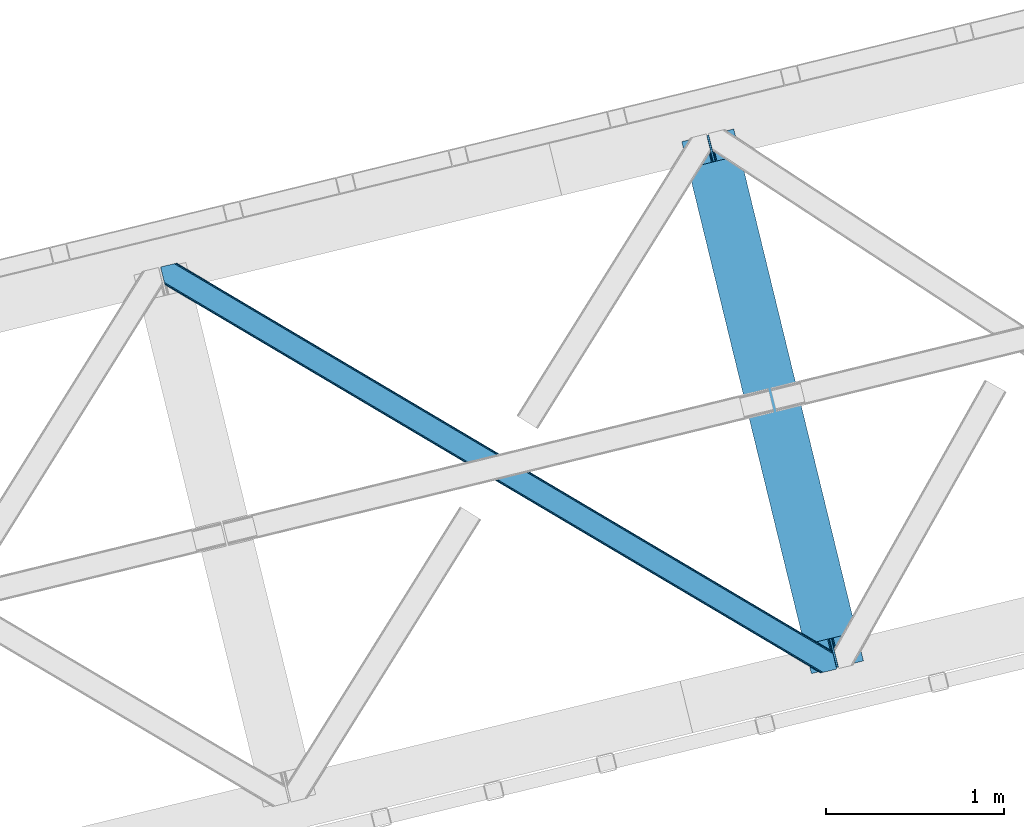
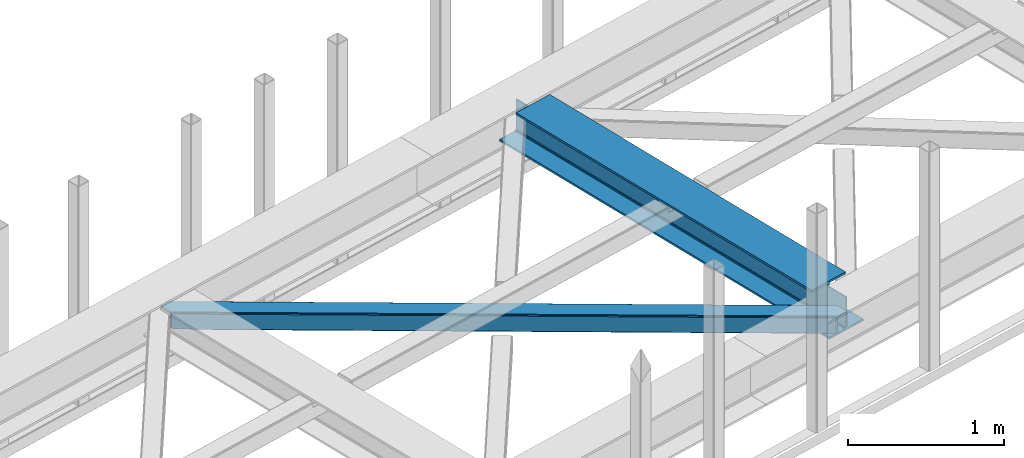
# One storey, part 52 of 67: 1 beam, 1 member.
"""IFC4 building model written with IfcOpenShell, lengths in millimetres."""

from ifc_helpers import new_model, entity, si_unit, converted_unit, derived_unit, direction, frame, origin, place, context, subcontext, project, spatial, triangles, polygons, material, type_object, element, save


model = new_model("IFC4")

# Units and contexts
model_context = context("Model", 3, precision=0.01, world=origin(), true_north=direction((6.12303176911189e-17, 1.0)))
plan_context = context("Plan", 3, precision=0.01, world=origin(), true_north=direction((6.12303176911189e-17, 1.0)))
body_context = subcontext(model_context, "Body", "Model", "MODEL_VIEW")
ifc_project = project(units=[si_unit("LENGTHUNIT", "METRE", prefix="MILLI"), si_unit("AREAUNIT", "SQUARE_METRE"), si_unit("VOLUMEUNIT", "CUBIC_METRE"), converted_unit("PLANEANGLEUNIT", "DEGREE", entity("IfcRatioMeasure", 0.0174532925199433), si_unit("PLANEANGLEUNIT", "RADIAN"), dimensions=[0, 0, 0, 0, 0, 0, 0]), si_unit("MASSUNIT", "GRAM", prefix="KILO"), derived_unit("MASSDENSITYUNIT", [(si_unit("MASSUNIT", "GRAM", prefix="KILO"), 1), (si_unit("LENGTHUNIT", "METRE"), -3)]), derived_unit("MOMENTOFINERTIAUNIT", [(si_unit("LENGTHUNIT", "METRE"), 4)]), si_unit("TIMEUNIT", "SECOND"), si_unit("FREQUENCYUNIT", "HERTZ"), si_unit("THERMODYNAMICTEMPERATUREUNIT", "DEGREE_CELSIUS"), derived_unit("THERMALTRANSMITTANCEUNIT", [(si_unit("MASSUNIT", "GRAM", prefix="KILO"), 1), (si_unit("THERMODYNAMICTEMPERATUREUNIT", "KELVIN"), -1), (si_unit("TIMEUNIT", "SECOND"), -3)]), derived_unit("VOLUMETRICFLOWRATEUNIT", [(si_unit("LENGTHUNIT", "METRE"), 3), (si_unit("TIMEUNIT", "SECOND"), -1)]), derived_unit("MASSFLOWRATEUNIT", [(si_unit("MASSUNIT", "GRAM", prefix="KILO"), 1), (si_unit("TIMEUNIT", "SECOND"), -1)]), derived_unit("ROTATIONALFREQUENCYUNIT", [(si_unit("TIMEUNIT", "SECOND"), -1)]), si_unit("ELECTRICCURRENTUNIT", "AMPERE"), si_unit("ELECTRICVOLTAGEUNIT", "VOLT"), si_unit("POWERUNIT", "WATT"), si_unit("FORCEUNIT", "NEWTON", prefix="KILO"), si_unit("ILLUMINANCEUNIT", "LUX"), si_unit("LUMINOUSFLUXUNIT", "LUMEN"), si_unit("LUMINOUSINTENSITYUNIT", "CANDELA"), derived_unit("USERDEFINED", [(si_unit("MASSUNIT", "GRAM", prefix="KILO"), -1), (si_unit("LENGTHUNIT", "METRE"), -2), (si_unit("TIMEUNIT", "SECOND"), 3), (si_unit("LUMINOUSFLUXUNIT", "LUMEN"), 1)]), derived_unit("LINEARVELOCITYUNIT", [(si_unit("LENGTHUNIT", "METRE"), 1), (si_unit("TIMEUNIT", "SECOND"), -1)]), si_unit("PRESSUREUNIT", "PASCAL"), derived_unit("USERDEFINED", [(si_unit("LENGTHUNIT", "METRE"), -2), (si_unit("MASSUNIT", "GRAM", prefix="KILO"), 1), (si_unit("TIMEUNIT", "SECOND"), -2)]), derived_unit("LINEARFORCEUNIT", [(si_unit("MASSUNIT", "GRAM", prefix="KILO"), 1), (si_unit("LENGTHUNIT", "METRE"), 1), (si_unit("TIMEUNIT", "SECOND"), -2), (si_unit("LENGTHUNIT", "METRE"), -1)]), derived_unit("PLANARFORCEUNIT", [(si_unit("MASSUNIT", "GRAM", prefix="KILO"), 1), (si_unit("LENGTHUNIT", "METRE"), 1), (si_unit("TIMEUNIT", "SECOND"), -2), (si_unit("LENGTHUNIT", "METRE"), -2)])], contexts=[model_context, plan_context])

# Site, building, storey
site_placement = place(None, origin())
site = spatial("IfcSite", under=ifc_project, at=site_placement, CompositionType="ELEMENT")
building_placement = place(site_placement, origin())
building = spatial("IfcBuilding", under=site, at=building_placement, CompositionType="ELEMENT")
storey_placement = place(building_placement, frame((0.0, 0.0, 19800.0)))
storey = spatial("IfcBuildingStorey", under=building, at=storey_placement, CompositionType="ELEMENT", Elevation=19800.0)

# Beam
ifc_material = material(Name="Metal painted (White)")
beam_type = type_object("IfcBeamType", PredefinedType="BEAM")
beam_placement = place(storey_placement, frame((-11884.4026274507, 14897.9803377072, 3807.02022389142)))
element("IfcBeam", 1, at=beam_placement, inside=storey, type_object=beam_type, material=ifc_material, ObjectType="Steel Beam", PredefinedType="BEAM", context=body_context, shape_type="Tessellation", body=[
    polygons([(1018.1664837833, 71.0478278971021, 15.5000000000008), (1018.1664837833, 71.0478278971021, 0.0), (291.465617442446, 3052.25531830421, 0.0), (291.465617442448, 3052.25531830421, 15.5000000000008), (894.779372399325, 40.970914087327, 15.5000000000008), (168.078506058474, 3022.17840449444, 15.5000000000008), (888.087028625373, 39.3395844888265, 16.8701684147984), (161.386162284522, 3020.54707489594, 16.8701684147984), (882.413533524757, 37.956610033654, 20.7720779386434), (155.712667183906, 3019.16410044077, 20.7720779386434), (878.622625296178, 37.0325360459184, 26.6116982174294), (151.921758955329, 3018.24002645303, 26.6116982174294), (877.291435352781, 36.7080444135029, 33.500000000001), (150.59056901193, 3017.91553482062, 33.500000000001), (140.875048430516, 3015.54727389071, 33.500000000001), (140.875048430518, 3015.54727389072, 259.000000000002), (150.590569011926, 3017.91553482062, 259.000000000002), (0.0, 2981.20749040711, 0.0), (0.0, 2981.20749040711, 15.4999999999965), (123.387111383964, 3011.28440421689, 15.5000000000008), (130.079455157922, 3012.91573381539, 16.8701684147984), (135.75295025854, 3014.29870827056, 20.7720779386434), (139.543858487119, 3015.2227822583, 26.6116982174294), (877.291435352779, 36.7080444135029, 259.000000000002), (867.575914771371, 34.3397834836014, 259.000000000002), (867.575914771369, 34.3397834836014, 33.500000000001), (866.24472482797, 34.0152918511859, 26.6116982174294), (862.453816599391, 33.0912178634502, 20.7720779386434), (856.780321498773, 31.70824340828, 16.8701684147984), (850.087977724817, 30.0769138097752, 15.5000000000008), (726.700866340853, 0.0, 15.4999999999965), (726.700866340851, 0.0, 0.0), (838.124523615903, 197.385937999177, 259.069791973884), (186.469722099962, 2870.72539801219, 259.000000000002), (186.693115201814, 2869.8089536072, 259.617303331124), (186.705504045441, 2869.75812937344, 266.500003008253), (837.979344808139, 197.981416001702, 266.500002998871), (837.979694928891, 197.97997969697, 260.000004007589), (828.499586345885, 194.645865944436, 259.006343171919), (828.276216326122, 195.562317481916, 259.617303331124), (828.263827482494, 195.613141715691, 266.500003008253), (176.989986719795, 2867.38985508742, 266.500002998871), (176.989636599043, 2867.39129139216, 260.000004007589), (176.844830940709, 2867.98534020595, 259.07612046749), (176.754201518552, 2868.35713708228, 259.000000000002), (839.310832678068, 198.30468544639, 273.388305639783), (843.101109266764, 199.231350618303, 279.227924098781), (848.774180214298, 200.616065081983, 283.129832400619), (855.466371895423, 202.248018612794, 284.500000377224), (978.853400583271, 232.325271667905, 284.500000138971), (978.85173077662, 232.332121736639, 299.999995328161), (687.386308679347, 161.283492472596, 299.999995890962), (687.387978485999, 161.276642403863, 284.500000701776), (810.775007173843, 191.353895458974, 284.500000463519), (817.467494069984, 192.984637925553, 283.129832461069), (823.141405718746, 194.365903570079, 279.227924137322), (826.93294050574, 195.287407219375, 273.388305663684), (175.658498849859, 2867.06658564273, 273.388305639783), (171.868222261163, 2866.13992047082, 279.227924098781), (166.195151313627, 2864.75520600715, 283.129832400619), (159.502959632495, 2863.12325247633, 284.500000377228), (36.1159309446555, 2833.04599942122, 284.500000138971), (36.117600751305, 2833.03914935249, 299.999995328161), (327.583022848578, 2904.08777861653, 299.999995890962), (327.58135304193, 2904.09462868526, 284.500000701776), (204.194324354075, 2874.01737563015, 284.500000463519), (197.501837457941, 2872.38663316357, 283.129832461069), (191.827925809183, 2871.00536751905, 279.227924137322), (188.036391022187, 2870.08386386975, 273.388305663684)], [[[1, 2, 3, 4]], [[5, 1, 4, 6]], [[7, 5, 6, 8]], [[9, 7, 8, 10]], [[11, 9, 10, 12]], [[13, 11, 12, 14]], [[15, 16, 17, 14, 12, 10, 8, 6, 4, 3, 18, 19, 20, 21, 22, 23]], [[13, 24, 25, 26, 27, 28, 29, 30, 31, 32, 2, 1, 5, 7, 9, 11]], [[2, 32, 18, 3]], [[32, 31, 19, 18]], [[31, 30, 20, 19]], [[27, 26, 15, 23]], [[28, 27, 23, 22]], [[29, 28, 22, 21]], [[30, 29, 21, 20]], [[33, 24, 13, 14, 17, 34, 35, 36, 37, 38]], [[25, 39, 40, 41, 42, 43, 44, 16, 15, 26]], [[39, 25, 24, 33]], [[45, 34, 17, 16]], [[41, 40, 38, 37, 46, 47, 48, 49, 50, 51, 52, 53, 54, 55, 56, 57]], [[42, 58, 59, 60, 61, 62, 63, 64, 65, 66, 67, 68, 69, 36, 35, 43]], [[46, 37, 36, 69]], [[47, 46, 69, 68]], [[48, 47, 68, 67]], [[49, 48, 67, 66]], [[50, 49, 66, 65]], [[51, 50, 65, 64]], [[52, 51, 64, 63]], [[53, 52, 63, 62]], [[54, 53, 62, 61]], [[55, 54, 61, 60]], [[56, 55, 60, 59]], [[57, 56, 59, 58]], [[41, 57, 58, 42]]], closed=False),
])

# Member
member_type = type_object("IfcMemberType", PredefinedType="BRACE")
member_placement = place(storey_placement, frame((-14805.0765472412, 14901.0346435547, 3822.99993896484)))
element("IfcMember", 2, at=member_placement, inside=storey, type_object=member_type, ObjectType="Steel Horizontal Brace", PredefinedType="BRACE", context=body_context, shape_type="Tessellation", body=[
    triangles([(3167.12877502441, 476.931353759765, 17.5012573242202), (3764.84694213867, 123.064581298828, 122.499499511719), (3764.84694213867, 123.064581298828, 17.5012573242202), (2547.33637390137, 843.862445068358, 17.5012573242202), (1927.54397277832, 1210.79469909668, 17.5012573242202), (91.5002288818359, 2297.77602539062, 122.499499511719), (687.959170532227, 1944.65920715332, 17.5012573242202), (91.5002288818359, 2297.77602539062, 17.5012573242202), (1307.75157165527, 1577.726953125, 17.5012573242202), (3770.63961181641, 99.2985900878903, 140.00075683594), (3768.42230529785, 108.393383789062, 138.668280029298), (76.4813781738285, 2294.11462097168, 138.668280029298), (67.1679931640629, 2291.8438293457, 140.00075683594), (3766.54335021973, 116.103378295898, 134.87548828125), (84.3750823974606, 2296.03892211914, 134.87548828125), (3765.28761291504, 121.255389404296, 129.196765136719), (89.6480163574215, 2297.32372741699, 129.196765136719), (3722.23907775879, 5.93103332519422, 140.00075683594), (18.7674591064442, 2198.47743530274, 140.00075683594), (3789.40823364258, 22.304452514647, 140.00075683594), (0.0, 2275.47157287598, 140.00075683594), (3697.90684204101, 0.0, 122.499499511719), (3699.75905456543, 0.451135253904795, 129.196765136719), (24.1206207275391, 2176.5194732666, 129.196765136719), (24.5612915039055, 2174.7114440918, 122.499499511719), (3705.0366394043, 1.73826599121094, 134.87548828125), (22.8637207031243, 2181.671484375, 134.87548828125), (3712.93150634766, 3.66256713867188, 138.668280029298), (20.9847656250004, 2189.38264160156, 138.668280029298), (1862.08168945313, 1086.85342712402, 17.5012573242202), (2481.94036560059, 719.882803344726, 17.5012573242202), (3101.79555358887, 352.912179565428, 17.5012573242202), (3697.90684204101, 0.0, 17.5012573242202), (1242.22650146484, 1453.82405090332, 17.5012573242202), (622.367825317382, 1820.79467468262, 17.5012573242202), (24.5612915039055, 2174.7114440918, 17.5012573242202), (74.6419555664052, 2293.66581115723, 127.873590087893), (66.7482513427731, 2291.74151000976, 131.668707275392), (79.9148895263661, 2294.9517791748, 122.197192382813), (57.4348663330074, 2289.47188110352, 133.001184082033), (0.0, 2275.47157287598, 133.001184082033), (81.7682647705078, 2295.40291442871, 115.499926757813), (81.7682647705078, 2295.40291442871, 24.5008300781265), (79.9148895263661, 2294.9517791748, 17.8035644531265), (89.5619750976566, 2297.30279846191, 10.8156188964858), (89.4724456787098, 2297.28070678711, 10.4993591308594), (74.1129180908192, 2293.53674926758, 12.4271484375022), (72.0351379394524, 2293.03096618652, 10.4993591308594), (1922.19197387695, 1205.8275604248, 24.5008300781265), (3767.16424255371, 113.558184814452, 115.499926757813), (2545.11092834473, 837.046582031249, 24.5008300781265), (3168.02523193359, 468.263278198241, 24.5008300781265), (3767.16424255371, 113.558184814452, 24.5008300781265), (1299.27650756836, 1574.60970153808, 24.5008300781265), (676.357553100586, 1943.39067993164, 24.5008300781265), (3767.60491333008, 111.748992919922, 122.197192382813), (3768.86065063477, 106.596981811523, 127.873590087893), (3770.73960571289, 98.886987304686, 131.668707275392), (3772.95691223145, 89.7910308837891, 133.001184082033), (3767.6932800293, 111.385061645507, 17.8686767578147), (3767.80141296387, 110.943228149414, 16.5199218750022), (3764.85508117676, 123.027374267578, 16.5199218750022), (3789.40823364258, 22.304452514647, 133.001184082033), (3731.97220458984, 8.30414428710901, 133.001184082033), (16.4501586914066, 2207.98383178711, 133.001184082033), (162.73657836914, 2253.90428466797, 10.4993591308594), (166.887487792968, 2236.87509155273, 10.4993591308594), (3722.66463317871, 6.03451538085938, 131.668707275392), (18.6674652099609, 2198.88903808594, 131.668707275392), (3714.76976623535, 4.11021423339844, 127.873590087893), (20.5464202880848, 2191.1790435791, 127.873590087893), (3709.49218139648, 2.82424621581958, 122.197192382813), (21.8033203124996, 2186.0270324707, 122.197192382813), (3707.63996887207, 2.3719482421875, 115.499926757813), (22.2439910888661, 2184.21784057617, 115.499926757813), (3114.18549499512, 353.713293457031, 24.5008300781265), (3707.63996887207, 2.3719482421875, 24.5008300781265), (2491.1200378418, 722.583801269531, 24.5008300781265), (1868.05458068848, 1091.45547180176, 24.5008300781265), (621.91901550293, 1829.19532470703, 24.5008300781265), (22.2439910888661, 2184.21784057617, 24.5008300781265), (1244.98447265625, 1460.32481689453, 24.5008300781265), (3709.49218139648, 2.82424621581958, 17.8035644531265), (3700.13461303711, 0.542990112304324, 10.8691040039084), (3700.58691101074, 0.653448486327761, 9.52034912109593), (3714.76976623535, 4.11021423339844, 12.1248413085959), (3719.39273986816, 5.23688964843677, 9.52034912109593), (21.7823913574211, 2186.11191101074, 17.817517089843), (21.7602996826172, 2186.20144042969, 17.5012573242202), (32.138735961913, 2171.84766540527, 10.8179443359368), (28.3459442138665, 2188.73965759277, 10.4993591308594), (27.0134674072269, 2187.35253295898, 12.1248413085959), (32.4968536376946, 2171.71046447754, 10.4993591308594), (203.965457153321, 2084.76809692383, 10.4993591308594), (208.116366577149, 2067.74006652832, 10.4993591308594), (164.096960449218, 2252.54739074707, 9.49942016601563), (168.582733154297, 2234.14502563476, 9.49942016601563), (168.16531677246, 2234.81824035645, 9.74591674804833), (163.767910766601, 2252.87527770996, 9.74126586914281), (167.737435913086, 2235.51122131347, 9.9993896484375), (163.419094848632, 2253.22641906738, 9.9993896484375), (167.304904174804, 2236.20303955078, 10.2528625488303), (163.065628051758, 2253.5775604248, 10.2598388671868), (209.161651611328, 2067.67146606445, 9.49942016601563), (209.134909057617, 2067.46682739258, 9.88311767578125), (204.681692504882, 2085.44363708496, 9.8528869628899), (208.802371215821, 2067.55635681152, 10.0831054687515), (204.68285522461, 2084.81111755371, 10.2063537597678), (208.448904418945, 2067.65053710937, 10.2993713378928), (204.323574829101, 2084.79018859863, 10.3528564453118), (204.67587890625, 2086.07499389648, 9.49942016601563), (3763.57841491699, 109.727023315429, 12.1248413085959), (3758.57058105469, 124.97144165039, 10.8714294433594), (3757.06369628906, 125.435366821288, 9.52034912109593), (3761.54249267578, 107.063232421875, 9.52034912109593), (3585.92297973633, 211.034793090819, 9.52034912109593), (3581.44418334961, 229.405764770507, 9.52034912109593), (3585.50556335449, 211.134786987304, 9.44360961914208), (3581.0453704834, 229.55343017578, 9.37384643554833), (3580.64539489746, 229.701095581055, 9.22734375000073), (3580.53726196289, 229.533663940429, 8.87387695312646), (3585.45556640625, 210.476687622069, 9.13897705078125), (3580.42564086914, 229.365069580077, 8.52041015625218), (3585.40440673828, 209.805798339843, 8.82736816406396), (3585.35324707031, 209.147698974608, 8.52041015625218), (3164.51730651856, 472.519995117187, 5.12526855468968), (3581.30116882324, 225.771102905273, 5.12526855468968), (3166.45090942383, 475.784912109375, 10.8039916992202), (687.281304931641, 1943.51276550293, 10.8039916992202), (685.347702026367, 1940.24784851074, 5.12526855468968), (165.152709960938, 2248.21625976562, 5.12526855468968), (682.454855346679, 1935.36326293945, 1.33247680664135), (167.031665039061, 2240.50510253906, 1.33247680664135), (679.044598388671, 1929.59966125488, 0.0), (169.248971557618, 2231.41030883789, 0.0), (3583.18128662109, 218.061108398437, 1.33247680664135), (3585.39743041992, 208.966314697265, 0.0), (3158.21420288086, 461.871807861327, 0.0), (3161.62562255859, 467.635409545897, 1.33247680664135), (2546.65850830078, 842.717166137694, 10.8039916992202), (1926.86610717774, 1209.64825744629, 10.8039916992202), (1307.07370605469, 1576.58051147461, 10.8039916992202), (2544.72490539551, 839.452249145506, 5.12526855468968), (1924.93250427246, 1206.38450317383, 5.12526855468968), (1305.14010314941, 1573.31675720215, 5.12526855468968), (2541.83322143555, 834.566500854491, 1.33247680664135), (1922.0408203125, 1201.49875488281, 1.33247680664135), (1302.24841918945, 1568.43100891113, 1.33247680664135), (2538.42180175781, 828.804061889648, 0.0), (1918.62940063477, 1195.73631591797, 0.0), (1298.83699951172, 1562.66856994629, 0.0), (3620.15809936524, 66.3657165527329, 0.0), (3110.71477661133, 367.971725463867, 0.0), (2490.85493774414, 734.942349243163, 0.0), (1870.99626159668, 1101.91181030273, 0.0), (631.282397460938, 1835.85305786133, 0.0), (1251.1410736084, 1468.88359680176, 0.0), (204.009640502929, 2088.80971069336, 0.0), (3167.34736633301, 467.117999267577, 17.8035644531265), (3165.41492614746, 463.853082275389, 12.1248413085959), (673.747247314453, 1938.98048400879, 12.1248413085959), (675.6796875, 1942.24540100098, 17.8035644531265), (670.854400634766, 1934.09473571777, 8.3320495605476), (169.397799682616, 2230.8022064209, 8.81806640624927), (171.566271972655, 2221.90391235351, 6.99957275390625), (3159.11065979004, 453.204895019531, 6.99957275390625), (3587.71589355469, 199.458755493164, 6.99957275390625), (3585.50556335449, 208.524481201172, 8.42274169921802), (3162.52207946777, 458.967333984374, 8.3320495605476), (667.442980957032, 1928.33229675293, 6.99957275390625), (2536.19635620117, 821.987036132812, 6.99957275390625), (2539.60777587891, 827.749475097655, 8.3320495605476), (1913.2774017334, 1190.76917724609, 6.99957275390625), (1916.68765869141, 1196.53161621094, 8.3320495605476), (1290.3619354248, 1559.55131835938, 6.99957275390625), (1293.77335510254, 1565.31375732422, 8.3320495605476), (2542.49945983887, 832.635223388672, 12.1248413085959), (1919.58050537109, 1201.41620178223, 12.1248413085959), (1296.66620178223, 1570.19950561523, 12.1248413085959), (2544.43306274414, 835.900140380858, 17.8035644531265), (1921.51410827637, 1204.68111877441, 17.8035644531265), (1298.59864196777, 1573.4632598877, 17.8035644531265), (201.692340087891, 2098.31610717773, 6.99957275390625), (203.86081237793, 2089.41781311035, 8.81806640624927), (206.226947021485, 2079.71491699219, 1.33247680664135), (208.105902099609, 2072.00492248535, 5.12526855468968), (2500.03460998535, 737.642184448241, 6.99957275390625), (3123.10006713867, 368.771676635741, 6.99957275390625), (1876.96915283203, 1106.51385498047, 6.99957275390625), (3617.8407989502, 75.8721130371086, 6.99957275390625), (630.833587646484, 1844.25487060547, 6.99957275390625), (1253.8990447998, 1475.38320007324, 6.99957275390625), (3119.68864746094, 363.009237670898, 8.3320495605476), (3620.56272583008, 65.041378784179, 8.90410766601781), (3620.20228271484, 66.183169555663, 8.52041015625218), (3116.79580078125, 358.123489379883, 12.1248413085959), (3621.05339355469, 64.3216552734375, 9.1087463378899), (3621.54754943848, 63.5914672851559, 9.31571044922021), (3622.03937988281, 62.8729064941399, 9.52034912109593), (3620.05112915039, 66.8075500488267, 8.42274169921802), (624.529321289063, 1833.60668334961, 12.1248413085959), (627.422167968751, 1838.49243164063, 8.3320495605476), (622.596881103516, 1830.34176635742, 17.8035644531265), (3114.8633605957, 354.858572387695, 17.8035644531265), (2491.79790344238, 723.730242919921, 17.8035644531265), (1868.73244628906, 1092.60075073242, 17.8035644531265), (1245.66233825684, 1461.47125854492, 17.8035644531265), (2493.73034362793, 726.993997192381, 12.1248413085959), (1870.66488647461, 1095.86566772461, 12.1248413085959), (1247.59477844238, 1464.73501281738, 12.1248413085959), (2496.62319030762, 731.879745483398, 8.3320495605476), (1873.5577331543, 1100.75141601562, 8.3320495605476), (1250.48762512207, 1469.6207611084, 8.3320495605476), (3102.47807006836, 354.05862121582, 10.8039916992202), (624.978131103515, 1825.20487060547, 5.12526855468968), (623.045690917968, 1821.94111633301, 10.8039916992202), (3626.5170135498, 44.5019348144524, 9.52034912109593), (3104.41051025391, 357.323538208007, 5.12526855468968), (3624.25436096191, 49.5597656249993, 5.12526855468968), (3625.13105163574, 45.9669616699211, 8.52041015625218), (3625.82635803223, 45.2344482421868, 9.02037963867406), (3622.37540588379, 57.2709228515614, 1.33247680664135), (3107.29870605469, 362.208123779295, 1.33247680664135), (627.870977783203, 1830.09061889648, 1.33247680664135), (2487.44468078613, 729.178747558593, 1.33247680664135), (1867.58484191895, 1096.14937133789, 1.33247680664135), (1247.73081665039, 1463.11999511719, 1.33247680664135), (2484.55183410645, 724.294161987304, 5.12526855468968), (1864.69199523926, 1091.26362304687, 5.12526855468968), (1244.8379699707, 1458.2354095459, 5.12526855468968), (2482.6193939209, 721.029244995116, 10.8039916992202), (1862.75955505371, 1087.99986877441, 10.8039916992202), (1242.90552978516, 1454.97049255371, 10.8039916992202)], [[1, 2, 3], [2, 1, 4], [2, 5, 6], [5, 2, 4], [7, 8, 6], [9, 6, 5], [6, 9, 7], [10, 11, 12], [12, 13, 10], [11, 14, 15], [15, 12, 11], [14, 16, 17], [17, 15, 14], [16, 2, 6], [6, 17, 16], [18, 10, 19], [18, 20, 10], [13, 19, 10], [21, 19, 13], [22, 23, 24], [24, 25, 22], [23, 26, 27], [27, 24, 23], [26, 28, 29], [29, 27, 26], [28, 18, 19], [19, 29, 28], [30, 22, 25], [22, 31, 32], [30, 31, 22], [32, 33, 22], [34, 25, 35], [25, 34, 30], [36, 35, 25], [37, 38, 12], [15, 37, 12], [15, 17, 39], [37, 15, 39], [39, 17, 6], [38, 13, 12], [21, 40, 41], [21, 13, 40], [38, 40, 13], [39, 6, 42], [43, 8, 44], [6, 43, 42], [8, 45, 44], [6, 8, 43], [46, 44, 45], [46, 47, 44], [46, 48, 47], [49, 50, 42], [50, 51, 52], [49, 51, 50], [52, 53, 50], [54, 42, 55], [42, 54, 49], [43, 55, 42], [50, 56, 42], [39, 42, 56], [56, 57, 39], [37, 39, 57], [57, 58, 37], [38, 37, 58], [58, 59, 38], [40, 38, 59], [57, 14, 11], [59, 58, 10], [58, 57, 11], [60, 61, 62], [63, 59, 20], [10, 20, 59], [58, 11, 10], [60, 3, 53], [2, 50, 53], [53, 3, 2], [60, 62, 3], [2, 56, 50], [56, 14, 57], [14, 56, 16], [2, 16, 56], [59, 64, 65], [64, 59, 63], [65, 40, 59], [41, 40, 65], [66, 67, 46], [48, 46, 67], [64, 68, 65], [69, 65, 68], [68, 70, 69], [71, 69, 70], [70, 72, 71], [73, 71, 72], [72, 74, 73], [75, 73, 74], [76, 74, 77], [74, 76, 78], [74, 79, 75], [79, 74, 78], [80, 81, 75], [82, 75, 79], [75, 82, 80], [70, 68, 28], [26, 70, 28], [26, 23, 72], [70, 26, 72], [72, 23, 22], [68, 18, 28], [20, 64, 63], [20, 18, 64], [68, 64, 18], [72, 22, 74], [77, 33, 83], [22, 77, 74], [33, 84, 83], [22, 33, 77], [85, 83, 84], [86, 83, 85], [87, 86, 85], [73, 75, 25], [25, 24, 73], [27, 73, 24], [73, 27, 71], [25, 81, 36], [88, 89, 36], [36, 81, 88], [75, 81, 25], [69, 29, 19], [21, 65, 19], [41, 65, 21], [69, 71, 29], [29, 71, 27], [65, 69, 19], [90, 91, 92], [90, 93, 91], [92, 36, 90], [89, 36, 92], [94, 95, 93], [93, 91, 94], [96, 97, 98], [98, 99, 96], [99, 98, 100], [100, 101, 99], [101, 100, 102], [102, 103, 101], [103, 102, 67], [67, 66, 103], [104, 105, 106], [105, 107, 108], [108, 107, 109], [110, 109, 95], [95, 94, 110], [109, 110, 108], [108, 106, 105], [106, 111, 104], [62, 112, 113], [112, 62, 61], [112, 114, 113], [112, 115, 114], [114, 115, 116], [116, 117, 114], [118, 119, 117], [120, 119, 118], [121, 120, 122], [123, 121, 124], [124, 125, 123], [122, 124, 121], [118, 122, 120], [117, 116, 118], [1, 3, 113], [3, 62, 113], [120, 121, 126], [123, 126, 121], [123, 127, 126], [128, 113, 117], [117, 126, 128], [117, 119, 126], [120, 126, 119], [113, 114, 117], [45, 129, 66], [129, 130, 131], [131, 96, 129], [129, 99, 101], [99, 129, 96], [129, 103, 66], [103, 129, 101], [129, 45, 8], [8, 7, 129], [66, 46, 45], [130, 132, 133], [133, 131, 130], [132, 134, 135], [135, 133, 132], [136, 137, 138], [138, 139, 136], [127, 136, 139], [139, 126, 127], [113, 128, 1], [1, 128, 4], [140, 4, 128], [4, 140, 5], [141, 5, 140], [5, 141, 9], [142, 9, 141], [9, 142, 7], [129, 7, 142], [128, 126, 143], [143, 140, 128], [140, 143, 141], [144, 141, 143], [141, 144, 142], [145, 142, 144], [142, 145, 130], [130, 129, 142], [126, 139, 146], [146, 143, 126], [143, 146, 147], [147, 144, 143], [144, 147, 145], [148, 145, 147], [145, 148, 130], [132, 130, 148], [139, 138, 149], [149, 146, 139], [146, 149, 150], [150, 147, 146], [147, 150, 148], [151, 148, 150], [148, 151, 134], [134, 132, 148], [137, 152, 153], [138, 153, 154], [153, 138, 137], [149, 155, 150], [154, 149, 138], [149, 154, 155], [156, 134, 151], [150, 157, 151], [157, 150, 155], [157, 156, 151], [158, 134, 156], [135, 134, 158], [159, 160, 112], [112, 61, 159], [159, 60, 53], [161, 162, 44], [98, 163, 100], [98, 97, 163], [163, 102, 100], [163, 67, 102], [97, 164, 163], [161, 47, 67], [67, 163, 161], [47, 48, 67], [163, 164, 165], [166, 167, 168], [160, 118, 116], [116, 112, 160], [116, 115, 112], [169, 168, 125], [125, 160, 169], [124, 122, 160], [122, 118, 160], [160, 125, 124], [168, 169, 166], [165, 170, 163], [44, 47, 161], [162, 55, 43], [43, 44, 162], [53, 52, 159], [61, 60, 159], [166, 169, 171], [172, 171, 169], [171, 172, 173], [174, 173, 172], [173, 174, 175], [176, 175, 174], [175, 176, 163], [163, 170, 175], [169, 160, 177], [177, 172, 169], [172, 177, 178], [178, 174, 172], [174, 178, 179], [179, 176, 174], [176, 179, 163], [161, 163, 179], [160, 159, 177], [180, 177, 159], [177, 180, 181], [181, 178, 177], [178, 181, 182], [182, 179, 178], [179, 182, 162], [162, 161, 179], [159, 52, 180], [51, 180, 52], [180, 51, 181], [49, 181, 51], [181, 49, 182], [54, 182, 49], [182, 54, 162], [55, 162, 54], [97, 131, 133], [135, 97, 133], [165, 164, 135], [165, 135, 183], [131, 97, 96], [135, 164, 97], [183, 158, 184], [158, 185, 111], [158, 183, 135], [186, 111, 185], [158, 111, 184], [186, 104, 111], [187, 188, 166], [166, 171, 187], [171, 189, 187], [189, 171, 173], [188, 167, 166], [188, 190, 167], [170, 191, 175], [191, 170, 183], [165, 183, 170], [192, 175, 191], [173, 192, 189], [175, 192, 173], [193, 194, 195], [196, 197, 194], [196, 198, 197], [196, 199, 198], [194, 193, 196], [195, 200, 193], [86, 87, 199], [199, 196, 86], [193, 200, 190], [191, 183, 184], [201, 108, 110], [110, 94, 201], [94, 92, 201], [94, 91, 92], [202, 106, 108], [202, 111, 106], [202, 184, 111], [108, 201, 202], [203, 201, 92], [92, 89, 203], [203, 88, 81], [81, 80, 203], [89, 88, 203], [184, 202, 191], [190, 188, 193], [83, 86, 196], [196, 204, 83], [77, 83, 204], [204, 76, 77], [76, 204, 78], [205, 78, 204], [78, 205, 206], [206, 79, 78], [79, 206, 207], [207, 82, 79], [82, 207, 203], [203, 80, 82], [204, 196, 208], [208, 205, 204], [205, 208, 209], [209, 206, 205], [206, 209, 207], [210, 207, 209], [207, 210, 201], [201, 203, 207], [196, 193, 208], [211, 208, 193], [208, 211, 209], [212, 209, 211], [209, 212, 213], [213, 210, 209], [210, 213, 202], [202, 201, 210], [193, 188, 187], [187, 211, 193], [211, 187, 189], [189, 212, 211], [212, 189, 213], [192, 213, 189], [213, 192, 191], [191, 202, 213], [214, 84, 33], [35, 36, 90], [215, 105, 104], [216, 90, 95], [95, 215, 216], [95, 107, 215], [104, 186, 215], [84, 214, 217], [214, 218, 219], [219, 220, 214], [221, 217, 214], [214, 220, 221], [217, 85, 84], [222, 219, 218], [218, 223, 222], [152, 222, 223], [223, 153, 152], [156, 224, 185], [185, 158, 156], [224, 215, 186], [186, 185, 224], [90, 216, 35], [33, 32, 214], [153, 223, 225], [225, 154, 153], [154, 225, 226], [226, 155, 154], [155, 226, 227], [227, 157, 155], [157, 227, 224], [224, 156, 157], [223, 218, 225], [228, 225, 218], [225, 228, 226], [229, 226, 228], [226, 229, 227], [230, 227, 229], [227, 230, 224], [215, 224, 230], [218, 214, 228], [231, 228, 214], [228, 231, 232], [232, 229, 228], [229, 232, 230], [233, 230, 232], [230, 233, 216], [216, 215, 230], [214, 32, 31], [31, 231, 214], [231, 31, 30], [30, 232, 231], [232, 30, 233], [34, 233, 30], [233, 34, 216], [35, 216, 34], [137, 167, 190], [125, 127, 123], [137, 125, 167], [125, 136, 127], [125, 137, 136], [152, 137, 190], [195, 152, 190], [219, 195, 220], [195, 222, 152], [195, 219, 222], [220, 195, 194], [221, 194, 197], [221, 197, 198], [217, 198, 199], [87, 85, 199], [217, 199, 85]]),
])

save(model, "model.ifc")
